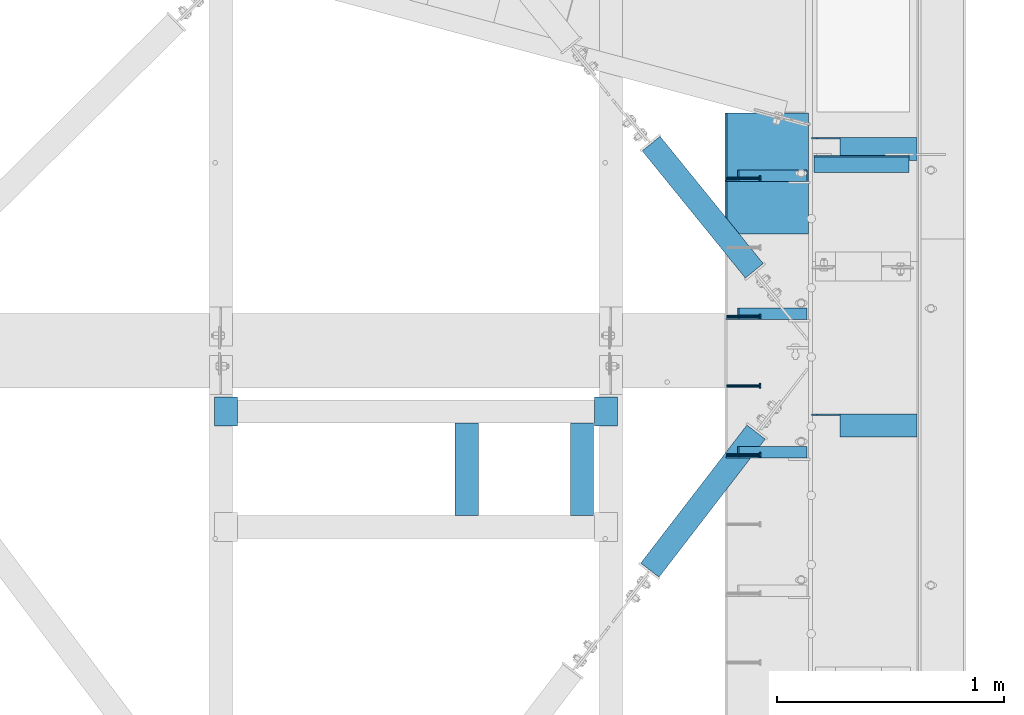
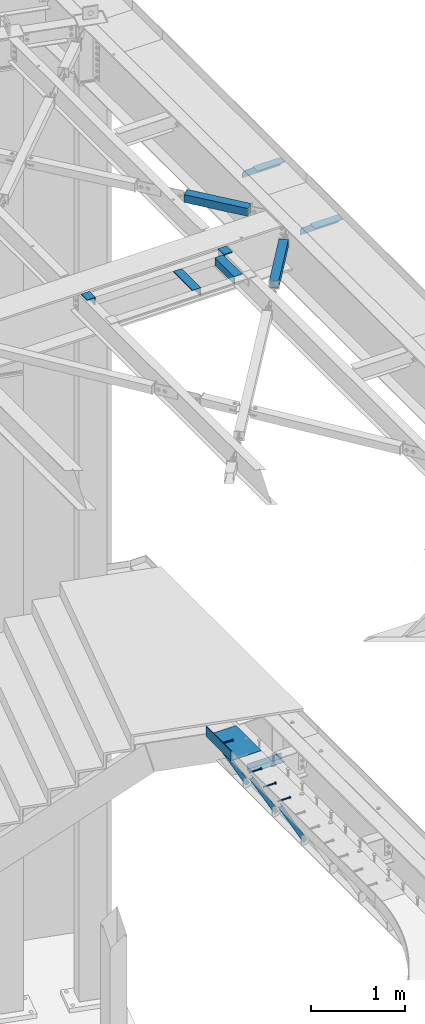
# One storey, part 1381 of 1763: 14 beams, 3 members, 10 elements without a shape of their own.
"""IFC2X3 building model written with IfcOpenShell, lengths in millimetres."""

import ifcopenshell
import ifcopenshell.guid

model = None  # the IFC model being written
_history = None  # IfcOwnerHistory: only IFC2X3 demands one
_inside = {}  # id of a spatial element -> (the spatial element, [elements in it])
_under = {}  # id of a project, library or spatial element -> (it, [spatial elements below it])
_declared = {}  # id of a project -> (the project, [libraries it declares])
_typed = {}  # id of a type object -> (the type object, [elements of that type])
_made_of = {}  # id of a material, layer set ... -> (it, [elements and type objects made of it])


def new_model(schema):
    """Start an empty IFC model of exactly this schema.

    Asked for "IFC4X3", IfcOpenShell would pick the latest addendum, in which some entities
    have other attributes; the version numbers below select the first issue.
    IFC2X3 requires an IfcOwnerHistory on every rooted entity: one is made here for all.
    """
    global model, _history
    if schema == "IFC4X3":
        model = ifcopenshell.file(schema_version=(4, 3, 0, 0))
    else:
        model = ifcopenshell.file(schema=schema)
    _inside.clear()
    _under.clear()
    _declared.clear()
    _typed.clear()
    _made_of.clear()
    _history = None
    if model.schema == "IFC2X3":
        org = make("IfcOrganization", Name="unknown")
        user = make(
            "IfcPersonAndOrganization",
            ThePerson=make("IfcPerson", FamilyName="unknown"),
            TheOrganization=org,
        )
        app = make(
            "IfcApplication",
            ApplicationDeveloper=org,
            Version="unknown",
            ApplicationFullName="unknown",
            ApplicationIdentifier="unknown",
        )
        _history = make(
            "IfcOwnerHistory",
            OwningUser=user,
            OwningApplication=app,
            ChangeAction="ADDED",
            CreationDate=0,
        )
    return model


def make(cls, **values):
    """One entity of the class cls with the attributes given. An attribute that is None is left unset."""
    return model.create_entity(
        cls, **{name: value for name, value in values.items() if value is not None}
    )


def rooted(cls, **values):
    """An entity with a GlobalId (a new one), such as an element, a storey or a relation."""
    return make(cls, GlobalId=ifcopenshell.guid.new(), OwnerHistory=_history, **values)


def si_unit(unit_type, name, prefix=None):
    """IfcSIUnit, for example si_unit("LENGTHUNIT", "METRE", prefix="MILLI")."""
    return make("IfcSIUnit", UnitType=unit_type, Prefix=prefix, Name=name)


def assignment(units):
    """IfcUnitAssignment: the units of a project."""
    return None if units is None else make("IfcUnitAssignment", Units=units)


def point(xyz):
    """IfcCartesianPoint."""
    return None if xyz is None else make("IfcCartesianPoint", Coordinates=xyz)


def direction(xyz):
    """IfcDirection."""
    return None if xyz is None else make("IfcDirection", DirectionRatios=xyz)


def frame(location, z_axis=None, x_axis=None):
    """IfcAxis2Placement3D, a coordinate frame: its origin and axes. An axis left out is left unset."""
    return make(
        "IfcAxis2Placement3D",
        Location=point(location),
        Axis=direction(z_axis),
        RefDirection=direction(x_axis),
    )


def origin_with_axes():
    """The frame at (0, 0, 0) with the z axis (0, 0, 1) and the x axis (1, 0, 0) written out."""
    return frame((0.0, 0.0, 0.0), z_axis=(0.0, 0.0, 1.0), x_axis=(1.0, 0.0, 0.0))


def place(relative_to, where):
    """IfcLocalPlacement: puts the frame where relative to a parent placement (None: the world)."""
    return make(
        "IfcLocalPlacement", PlacementRelTo=relative_to, RelativePlacement=where
    )


def context(
    kind, dimensions, precision=None, world=None, true_north=None, identifier=None
):
    """IfcGeometricRepresentationContext, for example the 3D "Model" context."""
    return make(
        "IfcGeometricRepresentationContext",
        ContextIdentifier=identifier,
        ContextType=kind,
        CoordinateSpaceDimension=dimensions,
        Precision=precision,
        WorldCoordinateSystem=world,
        TrueNorth=true_north,
    )


def subcontext(parent, identifier, kind, view, scale=None):
    """IfcGeometricRepresentationSubContext, for example "Body" below "Model"."""
    return make(
        "IfcGeometricRepresentationSubContext",
        ContextIdentifier=identifier,
        ContextType=kind,
        ParentContext=parent,
        TargetScale=scale,
        TargetView=view,
    )


def project(units=None, contexts=None):
    """IfcProject with its units and contexts."""
    return rooted(
        "IfcProject",
        Name="project",
        RepresentationContexts=contexts,
        UnitsInContext=assignment(units),
    )


def spatial(cls, under=None, at=None, **own):
    """A site, building, storey or space (cls), placed at a placement, below another one or the project."""
    s = rooted(cls, ObjectPlacement=at, **own)
    if under is not None:
        _under.setdefault(under.id(), (under, []))[1].append(s)
    return s


def faces_of(points, faces, orient=None, outer=None):
    """IfcFace entities. A face is a list of loops; a loop is a list of indices into points, from 0.

    orient and outer hold one flag for each loop. By default every Orientation is true, the
    first loop of a face is its IfcFaceOuterBound and the others are IfcFaceBound.
    """
    made = []
    for i, loops in enumerate(faces):
        bounds = []
        for j, loop in enumerate(loops):
            is_outer = j == 0 if outer is None else outer[i][j]
            bounds.append(
                make(
                    "IfcFaceOuterBound" if is_outer else "IfcFaceBound",
                    Bound=make("IfcPolyLoop", Polygon=[points[k] for k in loop]),
                    Orientation=True if orient is None else orient[i][j],
                )
            )
        made.append(make("IfcFace", Bounds=bounds))
    return made


def faceted_brep(points, faces, orient=None, outer=None, voids=None):
    """IfcFacetedBrep: a solid bounded by flat faces; with voids (closed shells), ...WithVoids."""
    shared = [point(p) for p in points]
    hull = make("IfcClosedShell", CfsFaces=faces_of(shared, faces, orient, outer))
    if voids is None:
        return make("IfcFacetedBrep", Outer=hull)
    return make(
        "IfcFacetedBrepWithVoids",
        Outer=hull,
        Voids=[
            make(cls, CfsFaces=faces_of(shared, fs, o, b)) for cls, fs, o, b in voids
        ],
    )


def shape(context_of_items, identifier, shape_type, items):
    """IfcShapeRepresentation: the items that make up one representation, for example the "Body"."""
    return make(
        "IfcShapeRepresentation",
        ContextOfItems=context_of_items,
        RepresentationIdentifier=identifier,
        RepresentationType=shape_type,
        Items=items,
    )


def material(Name=None, Category=None):
    """IfcMaterial."""
    return make("IfcMaterial", Name=Name, Category=Category)


def made_of(thing, what):
    """Note that an element or type object is made of a material, layer set ...; save() writes the relation."""
    if what is not None:
        _made_of.setdefault(what.id(), (what, []))[1].append(thing)
    return thing


def type_object(cls, material=None, **own):
    """A type object (cls), such as IfcWallType, which elements share."""
    return made_of(rooted(cls, **own), material)


def element(
    cls,
    number,
    at=None,
    inside=None,
    cuts=None,
    type_object=None,
    material=None,
    context=None,
    identifier="Body",
    shape_type=None,
    held_by="IfcProductDefinitionShape",
    body=None,
    shapes=None,
    **own,
):
    """One element of the class cls, such as IfcWall. Its Tag is "e" and its number.

    at: its placement. inside: the storey or other place that contains it. cuts: it is an
    opening in that element (IfcRelVoidsElement). A single representation is given by context,
    identifier, shape_type and body (its items); several are given by shapes. held_by: the class
    of the entity that holds the representations. save() writes the other relations.
    """
    e = rooted(cls, Tag="e%d" % number, ObjectPlacement=at, **own)
    if body is not None:
        shapes = [shape(context, identifier, shape_type, body)]
    if shapes is not None:
        e.Representation = make(held_by, Representations=shapes)
    if inside is not None:
        _inside.setdefault(inside.id(), (inside, []))[1].append(e)
    if cuts is not None:
        rooted(
            "IfcRelVoidsElement", RelatingBuildingElement=cuts, RelatedOpeningElement=e
        )
    if type_object is not None:
        _typed.setdefault(type_object.id(), (type_object, []))[1].append(e)
    return made_of(e, material)


def aggregate(whole, parts):
    """IfcRelAggregates: a whole, such as a stair, and the parts it consists of."""
    return rooted("IfcRelAggregates", RelatingObject=whole, RelatedObjects=parts)


def save(model, path):
    """Write the relations noted so far, then the file.

    IfcRelAggregates (storeys below a building ...), IfcRelContainedInSpatialStructure (elements
    in a storey), IfcRelDefinesByType, IfcRelAssociatesMaterial and IfcRelDeclares: one each for
    every whole, place, type object, material and project.
    """
    for whole, parts in _under.values():
        aggregate(whole, parts)
    for where, things in _inside.values():
        rooted(
            "IfcRelContainedInSpatialStructure",
            RelatedElements=things,
            RelatingStructure=where,
        )
    for kind, things in _typed.values():
        rooted("IfcRelDefinesByType", RelatedObjects=things, RelatingType=kind)
    for what, things in _made_of.values():
        rooted("IfcRelAssociatesMaterial", RelatedObjects=things, RelatingMaterial=what)
    for by, libraries in _declared.values():
        rooted("IfcRelDeclares", RelatingContext=by, RelatedDefinitions=libraries)
    model.write(path)


model = new_model("IFC2X3")

# Units and contexts
model_context = context("Model", 3, precision=1e-05, world=origin_with_axes())
body_context = subcontext(model_context, "Body", "Model", "MODEL_VIEW")
ifc_project = project(units=[si_unit("LENGTHUNIT", "METRE", prefix="MILLI"), si_unit("AREAUNIT", "SQUARE_METRE"), si_unit("VOLUMEUNIT", "CUBIC_METRE"), si_unit("MASSUNIT", "GRAM", prefix="KILO"), si_unit("TIMEUNIT", "SECOND"), si_unit("PLANEANGLEUNIT", "RADIAN"), si_unit("SOLIDANGLEUNIT", "STERADIAN"), si_unit("THERMODYNAMICTEMPERATUREUNIT", "DEGREE_CELSIUS"), si_unit("LUMINOUSINTENSITYUNIT", "LUMEN")], contexts=[model_context])

# Site, building, storey
site_placement = place(None, origin_with_axes())
site = spatial("IfcSite", under=ifc_project, at=site_placement, CompositionType="ELEMENT")
building_placement = place(site_placement, origin_with_axes())
building = spatial("IfcBuilding", under=site, at=building_placement, Name="Undefined", CompositionType="ELEMENT")
storey_placement = place(building_placement, origin_with_axes())
storey = spatial("IfcBuildingStorey", under=building, at=storey_placement, Name="Undefined", CompositionType="ELEMENT", Elevation=0.0)

# Assembly, beam
assembly_1_placement = place(storey_placement, origin_with_axes())
assembly_1 = element("IfcElementAssembly", 1, at=assembly_1_placement, inside=storey, Name="HEADED STUD ANCHOR", AssemblyPlace="NOTDEFINED", PredefinedType="RIGID_FRAME")
ifc_material_1 = material(Name="STEEL/A108")
beam_type_1 = type_object("IfcBeamType", PredefinedType="NOTDEFINED")
beam_1_placement = place(assembly_1_placement, frame((-22037.1277822587, 58462.06875, 5264.15000152588), z_axis=(0.0, 0.0, 1.0), x_axis=(1.0, 0.0, 0.0)))
beam_1 = element("IfcBeam", 2, at=beam_1_placement, type_object=beam_type_1, material=ifc_material_1, Name="HEADED STUD ANCHOR", context=body_context, shape_type="Brep", body=[
    faceted_brep([(0.0, -3.1800000667572, 5.5), (0.0, -5.5, 3.1800000667572), (141.732000000002, -5.5, 3.1800000667572), (141.732000000002, -3.1800000667572, 5.5), (0.0, -6.34999999999491, 1.45519152283669e-11), (141.732000000002, -6.34999990463257, 0.0), (0.0, -5.5, -3.1800000667572), (141.732000000002, -5.5, -3.1800000667572), (0.0, -3.1800000667572, -5.5), (141.732000000002, -3.1800000667572, -5.5), (0.0, 0.0, -6.34999990463257), (141.732000000002, 0.0, -6.34999990463257), (0.0, 3.1800000667572, -5.5), (141.732000000002, 3.1800000667572, -5.5), (0.0, 5.5, -3.1800000667572), (141.732000000002, 5.5, -3.1800000667572), (0.0, 6.34999999999491, -2.91038304567337e-11), (141.732000000002, 6.34999990463257, 0.0), (0.0, 5.5, 3.1800000667572), (141.732000000002, 5.5, 3.1800000667572), (0.0, 3.1800000667572, 5.5), (141.732000000002, 3.1800000667572, 5.5), (0.0, 0.0, 6.34999990463257), (141.732000000002, 0.0, 6.34999990463257), (144.780000000001, -10.9899997711182, 6.34999990463257), (144.780000000001, -6.34000015258789, 10.9899997711182), (144.780000000001, -12.6999998092651, 0.0), (144.780000000001, -10.9899997711182, -6.34999990463257), (144.780000000001, -6.34000015258789, -10.9899997711182), (144.780000000001, 0.0, -12.6899995803833), (144.780000000001, 6.34000015258789, -10.9899997711182), (144.780000000001, 10.9899997711182, -6.34999990463257), (144.780000000001, 12.6999998092651, 0.0), (144.780000000001, 10.9899997711182, 6.34999990463257), (144.780000000001, 6.34000015258789, 10.9899997711182), (144.780000000001, 0.0, 12.6899995803833), (152.400000000001, -10.9899997711182, 6.34999990463257), (152.400000000001, -6.34000015258789, 10.9899997711182), (152.400000000001, -12.6999998092651, 0.0), (152.400000000001, -10.9899997711182, -6.34999990463257), (152.400000000001, -6.34000015258789, -10.9899997711182), (152.400000000001, 0.0, -12.6899995803833), (152.400000000001, 6.34000015258789, -10.9899997711182), (152.400000000001, 10.9899997711182, -6.34999990463257), (152.400000000001, 12.6999998092651, 0.0), (152.400000000001, 10.9899997711182, 6.34999990463257), (152.400000000001, 6.34000015258789, 10.9899997711182), (152.400000000001, 0.0, 12.6899995803833)], [[[0, 1, 2, 3]], [[1, 4, 5, 2]], [[4, 6, 7, 5]], [[6, 8, 9, 7]], [[8, 10, 11, 9]], [[10, 12, 13, 11]], [[12, 14, 15, 13]], [[14, 16, 17, 15]], [[16, 18, 19, 17]], [[18, 20, 21, 19]], [[20, 22, 23, 21]], [[22, 0, 3, 23]], [[22, 20, 18, 16, 14, 12, 10, 8, 6, 4, 1, 0]], [[3, 2, 24, 25]], [[2, 5, 26, 24]], [[5, 7, 27, 26]], [[7, 9, 28, 27]], [[9, 11, 29, 28]], [[11, 13, 30, 29]], [[13, 15, 31, 30]], [[15, 17, 32, 31]], [[17, 19, 33, 32]], [[19, 21, 34, 33]], [[21, 23, 35, 34]], [[23, 3, 25, 35]], [[25, 24, 36, 37]], [[24, 26, 38, 36]], [[26, 27, 39, 38]], [[27, 28, 40, 39]], [[28, 29, 41, 40]], [[29, 30, 42, 41]], [[30, 31, 43, 42]], [[31, 32, 44, 43]], [[32, 33, 45, 44]], [[33, 34, 46, 45]], [[34, 35, 47, 46]], [[35, 25, 37, 47]], [[38, 39, 40, 41, 42, 43, 44, 45, 46, 47, 37, 36]]]),
])
aggregate(assembly_1, [beam_1])

assembly_2_placement = place(storey_placement, origin_with_axes())
assembly_2 = element("IfcElementAssembly", 3, at=assembly_2_placement, inside=storey, Name="HEADED STUD ANCHOR", AssemblyPlace="NOTDEFINED", PredefinedType="RIGID_FRAME")
beam_2_placement = place(assembly_2_placement, frame((-22037.1277822587, 57852.46875, 5264.15000152588), z_axis=(0.0, 0.0, 1.0), x_axis=(1.0, 0.0, 0.0)))
beam_2 = element("IfcBeam", 4, at=beam_2_placement, type_object=beam_type_1, material=ifc_material_1, Name="HEADED STUD ANCHOR", context=body_context, shape_type="Brep", body=[
    faceted_brep([(0.0, -3.1800000667572, 5.5), (0.0, -5.5, 3.1800000667572), (141.732000000002, -5.5, 3.1800000667572), (141.732000000002, -3.1800000667572, 5.5), (0.0, -6.34999999999491, 1.45519152283669e-11), (141.732000000002, -6.34999990463257, 0.0), (0.0, -5.5, -3.1800000667572), (141.732000000002, -5.5, -3.1800000667572), (0.0, -3.1800000667572, -5.5), (141.732000000002, -3.1800000667572, -5.5), (0.0, 0.0, -6.34999990463257), (141.732000000002, 0.0, -6.34999990463257), (0.0, 3.1800000667572, -5.5), (141.732000000002, 3.1800000667572, -5.5), (0.0, 5.5, -3.1800000667572), (141.732000000002, 5.5, -3.1800000667572), (0.0, 6.34999999999491, -2.91038304567337e-11), (141.732000000002, 6.34999990463257, 0.0), (0.0, 5.5, 3.1800000667572), (141.732000000002, 5.5, 3.1800000667572), (0.0, 3.1800000667572, 5.5), (141.732000000002, 3.1800000667572, 5.5), (0.0, 0.0, 6.34999990463257), (141.732000000002, 0.0, 6.34999990463257), (144.780000000001, -10.9899997711182, 6.34999990463257), (144.780000000001, -6.34000015258789, 10.9899997711182), (144.780000000001, -12.6999998092651, 0.0), (144.780000000001, -10.9899997711182, -6.34999990463257), (144.780000000001, -6.34000015258789, -10.9899997711182), (144.780000000001, 0.0, -12.6899995803833), (144.780000000001, 6.34000015258789, -10.9899997711182), (144.780000000001, 10.9899997711182, -6.34999990463257), (144.780000000001, 12.6999998092651, 0.0), (144.780000000001, 10.9899997711182, 6.34999990463257), (144.780000000001, 6.34000015258789, 10.9899997711182), (144.780000000001, 0.0, 12.6899995803833), (152.400000000001, -10.9899997711182, 6.34999990463257), (152.400000000001, -6.34000015258789, 10.9899997711182), (152.400000000001, -12.6999998092651, 0.0), (152.400000000001, -10.9899997711182, -6.34999990463257), (152.400000000001, -6.34000015258789, -10.9899997711182), (152.400000000001, 0.0, -12.6899995803833), (152.400000000001, 6.34000015258789, -10.9899997711182), (152.400000000001, 10.9899997711182, -6.34999990463257), (152.400000000001, 12.6999998092651, 0.0), (152.400000000001, 10.9899997711182, 6.34999990463257), (152.400000000001, 6.34000015258789, 10.9899997711182), (152.400000000001, 0.0, 12.6899995803833)], [[[0, 1, 2, 3]], [[1, 4, 5, 2]], [[4, 6, 7, 5]], [[6, 8, 9, 7]], [[8, 10, 11, 9]], [[10, 12, 13, 11]], [[12, 14, 15, 13]], [[14, 16, 17, 15]], [[16, 18, 19, 17]], [[18, 20, 21, 19]], [[20, 22, 23, 21]], [[22, 0, 3, 23]], [[22, 20, 18, 16, 14, 12, 10, 8, 6, 4, 1, 0]], [[3, 2, 24, 25]], [[2, 5, 26, 24]], [[5, 7, 27, 26]], [[7, 9, 28, 27]], [[9, 11, 29, 28]], [[11, 13, 30, 29]], [[13, 15, 31, 30]], [[15, 17, 32, 31]], [[17, 19, 33, 32]], [[19, 21, 34, 33]], [[21, 23, 35, 34]], [[23, 3, 25, 35]], [[25, 24, 36, 37]], [[24, 26, 38, 36]], [[26, 27, 39, 38]], [[27, 28, 40, 39]], [[28, 29, 41, 40]], [[29, 30, 42, 41]], [[30, 31, 43, 42]], [[31, 32, 44, 43]], [[32, 33, 45, 44]], [[33, 34, 46, 45]], [[34, 35, 47, 46]], [[35, 25, 37, 47]], [[38, 39, 40, 41, 42, 43, 44, 45, 46, 47, 37, 36]]]),
])
aggregate(assembly_2, [beam_2])

assembly_3_placement = place(storey_placement, origin_with_axes())
assembly_3 = element("IfcElementAssembly", 5, at=assembly_3_placement, inside=storey, Name="HEADED STUD ANCHOR", AssemblyPlace="NOTDEFINED", PredefinedType="RIGID_FRAME")
beam_3_placement = place(assembly_3_placement, frame((-22037.1277822587, 57547.66875, 5264.15000152588), z_axis=(0.0, 0.0, 1.0), x_axis=(1.0, 0.0, 0.0)))
beam_3 = element("IfcBeam", 6, at=beam_3_placement, type_object=beam_type_1, material=ifc_material_1, Name="HEADED STUD ANCHOR", context=body_context, shape_type="Brep", body=[
    faceted_brep([(0.0, -3.1800000667572, 5.5), (0.0, -5.5, 3.1800000667572), (141.732000000002, -5.5, 3.1800000667572), (141.732000000002, -3.1800000667572, 5.5), (0.0, -6.34999999999491, 1.45519152283669e-11), (141.732000000002, -6.34999990463257, 0.0), (0.0, -5.5, -3.1800000667572), (141.732000000002, -5.5, -3.1800000667572), (0.0, -3.1800000667572, -5.5), (141.732000000002, -3.1800000667572, -5.5), (0.0, 0.0, -6.34999990463257), (141.732000000002, 0.0, -6.34999990463257), (0.0, 3.1800000667572, -5.5), (141.732000000002, 3.1800000667572, -5.5), (0.0, 5.5, -3.1800000667572), (141.732000000002, 5.5, -3.1800000667572), (0.0, 6.34999999999491, -2.91038304567337e-11), (141.732000000002, 6.34999990463257, 0.0), (0.0, 5.5, 3.1800000667572), (141.732000000002, 5.5, 3.1800000667572), (0.0, 3.1800000667572, 5.5), (141.732000000002, 3.1800000667572, 5.5), (0.0, 0.0, 6.34999990463257), (141.732000000002, 0.0, 6.34999990463257), (144.780000000001, -10.9899997711182, 6.34999990463257), (144.780000000001, -6.34000015258789, 10.9899997711182), (144.780000000001, -12.6999998092651, 0.0), (144.780000000001, -10.9899997711182, -6.34999990463257), (144.780000000001, -6.34000015258789, -10.9899997711182), (144.780000000001, 0.0, -12.6899995803833), (144.780000000001, 6.34000015258789, -10.9899997711182), (144.780000000001, 10.9899997711182, -6.34999990463257), (144.780000000001, 12.6999998092651, 0.0), (144.780000000001, 10.9899997711182, 6.34999990463257), (144.780000000001, 6.34000015258789, 10.9899997711182), (144.780000000001, 0.0, 12.6899995803833), (152.400000000001, -10.9899997711182, 6.34999990463257), (152.400000000001, -6.34000015258789, 10.9899997711182), (152.400000000001, -12.6999998092651, 0.0), (152.400000000001, -10.9899997711182, -6.34999990463257), (152.400000000001, -6.34000015258789, -10.9899997711182), (152.400000000001, 0.0, -12.6899995803833), (152.400000000001, 6.34000015258789, -10.9899997711182), (152.400000000001, 10.9899997711182, -6.34999990463257), (152.400000000001, 12.6999998092651, 0.0), (152.400000000001, 10.9899997711182, 6.34999990463257), (152.400000000001, 6.34000015258789, 10.9899997711182), (152.400000000001, 0.0, 12.6899995803833)], [[[0, 1, 2, 3]], [[1, 4, 5, 2]], [[4, 6, 7, 5]], [[6, 8, 9, 7]], [[8, 10, 11, 9]], [[10, 12, 13, 11]], [[12, 14, 15, 13]], [[14, 16, 17, 15]], [[16, 18, 19, 17]], [[18, 20, 21, 19]], [[20, 22, 23, 21]], [[22, 0, 3, 23]], [[22, 20, 18, 16, 14, 12, 10, 8, 6, 4, 1, 0]], [[3, 2, 24, 25]], [[2, 5, 26, 24]], [[5, 7, 27, 26]], [[7, 9, 28, 27]], [[9, 11, 29, 28]], [[11, 13, 30, 29]], [[13, 15, 31, 30]], [[15, 17, 32, 31]], [[17, 19, 33, 32]], [[19, 21, 34, 33]], [[21, 23, 35, 34]], [[23, 3, 25, 35]], [[25, 24, 36, 37]], [[24, 26, 38, 36]], [[26, 27, 39, 38]], [[27, 28, 40, 39]], [[28, 29, 41, 40]], [[29, 30, 42, 41]], [[30, 31, 43, 42]], [[31, 32, 44, 43]], [[32, 33, 45, 44]], [[33, 34, 46, 45]], [[34, 35, 47, 46]], [[35, 25, 37, 47]], [[38, 39, 40, 41, 42, 43, 44, 45, 46, 47, 37, 36]]]),
])
aggregate(assembly_3, [beam_3])

assembly_4_placement = place(storey_placement, origin_with_axes())
assembly_4 = element("IfcElementAssembly", 7, at=assembly_4_placement, inside=storey, Name="HEADED STUD ANCHOR", AssemblyPlace="NOTDEFINED", PredefinedType="RIGID_FRAME")
beam_4_placement = place(assembly_4_placement, frame((-22037.1277822587, 57242.86875, 5264.15000152588), z_axis=(0.0, 0.0, 1.0), x_axis=(1.0, 0.0, 0.0)))
beam_4 = element("IfcBeam", 8, at=beam_4_placement, type_object=beam_type_1, material=ifc_material_1, Name="HEADED STUD ANCHOR", context=body_context, shape_type="Brep", body=[
    faceted_brep([(0.0, -3.1800000667572, 5.5), (0.0, -5.5, 3.1800000667572), (141.732000000002, -5.5, 3.1800000667572), (141.732000000002, -3.1800000667572, 5.5), (0.0, -6.34999999999491, 1.45519152283669e-11), (141.732000000002, -6.34999990463257, 0.0), (0.0, -5.5, -3.1800000667572), (141.732000000002, -5.5, -3.1800000667572), (0.0, -3.1800000667572, -5.5), (141.732000000002, -3.1800000667572, -5.5), (0.0, 0.0, -6.34999990463257), (141.732000000002, 0.0, -6.34999990463257), (0.0, 3.1800000667572, -5.5), (141.732000000002, 3.1800000667572, -5.5), (0.0, 5.5, -3.1800000667572), (141.732000000002, 5.5, -3.1800000667572), (0.0, 6.34999999999491, -2.91038304567337e-11), (141.732000000002, 6.34999990463257, 0.0), (0.0, 5.5, 3.1800000667572), (141.732000000002, 5.5, 3.1800000667572), (0.0, 3.1800000667572, 5.5), (141.732000000002, 3.1800000667572, 5.5), (0.0, 0.0, 6.34999990463257), (141.732000000002, 0.0, 6.34999990463257), (144.780000000001, -10.9899997711182, 6.34999990463257), (144.780000000001, -6.34000015258789, 10.9899997711182), (144.780000000001, -12.6999998092651, 0.0), (144.780000000001, -10.9899997711182, -6.34999990463257), (144.780000000001, -6.34000015258789, -10.9899997711182), (144.780000000001, 0.0, -12.6899995803833), (144.780000000001, 6.34000015258789, -10.9899997711182), (144.780000000001, 10.9899997711182, -6.34999990463257), (144.780000000001, 12.6999998092651, 0.0), (144.780000000001, 10.9899997711182, 6.34999990463257), (144.780000000001, 6.34000015258789, 10.9899997711182), (144.780000000001, 0.0, 12.6899995803833), (152.400000000001, -10.9899997711182, 6.34999990463257), (152.400000000001, -6.34000015258789, 10.9899997711182), (152.400000000001, -12.6999998092651, 0.0), (152.400000000001, -10.9899997711182, -6.34999990463257), (152.400000000001, -6.34000015258789, -10.9899997711182), (152.400000000001, 0.0, -12.6899995803833), (152.400000000001, 6.34000015258789, -10.9899997711182), (152.400000000001, 10.9899997711182, -6.34999990463257), (152.400000000001, 12.6999998092651, 0.0), (152.400000000001, 10.9899997711182, 6.34999990463257), (152.400000000001, 6.34000015258789, 10.9899997711182), (152.400000000001, 0.0, 12.6899995803833)], [[[0, 1, 2, 3]], [[1, 4, 5, 2]], [[4, 6, 7, 5]], [[6, 8, 9, 7]], [[8, 10, 11, 9]], [[10, 12, 13, 11]], [[12, 14, 15, 13]], [[14, 16, 17, 15]], [[16, 18, 19, 17]], [[18, 20, 21, 19]], [[20, 22, 23, 21]], [[22, 0, 3, 23]], [[22, 20, 18, 16, 14, 12, 10, 8, 6, 4, 1, 0]], [[3, 2, 24, 25]], [[2, 5, 26, 24]], [[5, 7, 27, 26]], [[7, 9, 28, 27]], [[9, 11, 29, 28]], [[11, 13, 30, 29]], [[13, 15, 31, 30]], [[15, 17, 32, 31]], [[17, 19, 33, 32]], [[19, 21, 34, 33]], [[21, 23, 35, 34]], [[23, 3, 25, 35]], [[25, 24, 36, 37]], [[24, 26, 38, 36]], [[26, 27, 39, 38]], [[27, 28, 40, 39]], [[28, 29, 41, 40]], [[29, 30, 42, 41]], [[30, 31, 43, 42]], [[31, 32, 44, 43]], [[32, 33, 45, 44]], [[33, 34, 46, 45]], [[34, 35, 47, 46]], [[35, 25, 37, 47]], [[38, 39, 40, 41, 42, 43, 44, 45, 46, 47, 37, 36]]]),
])
aggregate(assembly_4, [beam_4])

# Assembly, members
assembly_5_placement = place(storey_placement, origin_with_axes())
assembly_5 = element("IfcElementAssembly", 9, at=assembly_5_placement, inside=storey, Name="BEAM", AssemblyPlace="NOTDEFINED", PredefinedType="RIGID_FRAME")
ifc_material_2 = material(Name="STEEL/A36")
member_type = type_object("IfcMemberType", Name="L2X2X1/4", PredefinedType="NOTDEFINED")
member_1_placement = place(assembly_5_placement, frame((-22018.0026564191, 57254.775, 5206.55507545536), z_axis=(-0.875905243340155, 0.0, -0.482483165187371), x_axis=(0.482483165187372, 0.0, -0.875905243340155)))
member_1 = element("IfcMember", 10, at=member_1_placement, type_object=member_type, material=ifc_material_2, Name="ANGLE", ObjectType="L2X2X1/4", context=body_context, shape_type="Brep", body=[
    faceted_brep([(27.9826493408473, 25.4000000000015, -25.4000000000015), (1.45519152283669e-11, 25.4000000000015, 25.3999999999796), (646.991234315485, 25.4000000000015, 25.4000000007727), (646.991234315505, 25.4000000000015, -25.3999999992993), (1.45519152283669e-11, 19.0499999999993, 25.3999999999796), (646.991234315485, 19.0500000000029, 25.4000000007727), (24.4848192607787, 19.0500000000029, -19.0499999999993), (646.991234315503, 19.0500000000029, -19.0499999992862), (24.4848192607787, -25.4000000000015, -19.0499999999993), (646.991234315503, -25.4000000000015, -19.0499999992862), (27.9826493408473, -25.4000000000015, -25.4000000000015), (646.991234315505, -25.4000000000015, -25.3999999992993)], [[[0, 1, 2, 3]], [[1, 4, 5, 2]], [[4, 6, 7, 5]], [[6, 8, 9, 7]], [[8, 10, 11, 9]], [[10, 0, 3, 11]], [[5, 7, 9, 11, 3, 2]], [[10, 8, 6, 4, 1, 0]]]),
])
member_2_placement = place(assembly_5_placement, frame((-22018.0026564191, 57864.375, 5206.55507545536), z_axis=(-0.875905243340155, 0.0, -0.482483165187371), x_axis=(0.482483165187372, 0.0, -0.875905243340155)))
member_2 = element("IfcMember", 11, at=member_2_placement, type_object=member_type, material=ifc_material_2, Name="ANGLE", ObjectType="L2X2X1/4", context=body_context, shape_type="Brep", body=[
    faceted_brep([(27.9826493408473, 25.4000000000015, -25.4000000000015), (1.45519152283669e-11, 25.4000000000015, 25.3999999999796), (646.991234315485, 25.4000000000015, 25.4000000007727), (646.991234315505, 25.4000000000015, -25.3999999992993), (1.45519152283669e-11, 19.0499999999993, 25.3999999999796), (646.991234315485, 19.0500000000029, 25.4000000007727), (24.4848192607787, 19.0500000000029, -19.0499999999993), (646.991234315503, 19.0500000000029, -19.0499999992862), (24.4848192607787, -25.4000000000015, -19.0499999999993), (646.991234315503, -25.4000000000015, -19.0499999992862), (27.9826493408473, -25.4000000000015, -25.4000000000015), (646.991234315505, -25.4000000000015, -25.3999999992993)], [[[0, 1, 2, 3]], [[1, 4, 5, 2]], [[4, 6, 7, 5]], [[6, 8, 9, 7]], [[8, 10, 11, 9]], [[10, 0, 3, 11]], [[5, 7, 9, 11, 3, 2]], [[10, 8, 6, 4, 1, 0]]]),
])
member_3_placement = place(assembly_5_placement, frame((-22018.0492336449, 58473.975, 5206.55507545536), z_axis=(-0.875905243340155, 0.0, -0.482483165187371), x_axis=(0.482483165187372, 0.0, -0.875905243340155)))
member_3 = element("IfcMember", 12, at=member_3_placement, type_object=member_type, material=ifc_material_2, Name="ANGLE", ObjectType="L2X2X1/4", context=body_context, shape_type="Brep", body=[
    faceted_brep([(27.9826493408473, 25.4000000000015, -25.4000000000015), (1.45519152283669e-11, 25.4000000000015, 25.3999999999796), (646.991234315485, 25.4000000000015, 25.4000000007727), (646.991234315505, 25.4000000000015, -25.3999999992993), (1.45519152283669e-11, 19.0499999999993, 25.3999999999796), (646.991234315485, 19.0500000000029, 25.4000000007727), (24.4848192607787, 19.0500000000029, -19.0499999999993), (646.991234315503, 19.0500000000029, -19.0499999992862), (24.4848192607787, -25.4000000000015, -19.0499999999993), (646.991234315503, -25.4000000000015, -19.0499999992862), (27.9826493408473, -25.4000000000015, -25.4000000000015), (646.991234315505, -25.4000000000015, -25.3999999992993)], [[[0, 1, 2, 3]], [[1, 4, 5, 2]], [[4, 6, 7, 5]], [[6, 8, 9, 7]], [[8, 10, 11, 9]], [[10, 0, 3, 11]], [[5, 7, 9, 11, 3, 2]], [[10, 8, 6, 4, 1, 0]]]),
])

# Assembly, beams
assembly_6_placement = place(storey_placement, origin_with_axes())
assembly_6 = element("IfcElementAssembly", 13, at=assembly_6_placement, inside=storey, Name="BEAM", AssemblyPlace="NOTDEFINED", PredefinedType="RIGID_FRAME")
beam_type_2 = type_object("IfcBeamType", Name="L4X4X1/4", PredefinedType="NOTDEFINED")
beam_5_placement = place(assembly_6_placement, frame((-21196.9646113448, 58591.4499880058, 12395.2), z_axis=(0.0, 0.0, -1.0), x_axis=(-1.0, 0.0, 0.0)))
beam_5 = element("IfcBeam", 14, at=beam_5_placement, type_object=beam_type_2, material=ifc_material_2, Name="BRACE", ObjectType="L4X4X1/4", context=body_context, shape_type="Brep", body=[
    faceted_brep([(1.96450855582952e-10, -50.8000000000338, -44.4499999999534), (2.11002770811319e-10, -50.8000000000357, -50.799999999952), (339.725506103507, -50.8000000000029, -50.7999999999993), (339.725506103507, -50.8000000000029, -44.4500000000007), (-3.63797880709171e-11, 50.8000000000011, -50.8000000000538), (339.725506103507, 50.8000000000029, -50.7999999999993), (339.725506103507, 44.4499999999971, -34.9250007629398), (339.725506103507, 50.8000000000029, -34.9250007629398), (441.325002944937, 50.8000000000029, -34.9250007629398), (441.325002944937, 44.4499999999971, -34.9250007629398), (339.725506103507, 44.4499999999971, -44.4500000000007), (-2.18278728425503e-11, 44.4500000000007, -44.450000000048), (-1.81898940354586e-10, 44.4500000000371, 50.7999999999374), (-1.96450855582952e-10, 50.8000000000393, 50.7999999999374), (466.725006103512, 44.4499999999971, 50.7999999999993), (466.725006103512, 50.8000000000029, 50.7999999999993), (466.725002563468, 50.8000000000029, -9.52499923706091), (466.725002563468, 44.4499999999971, -9.52499923706091)], [[[0, 1, 2, 3]], [[1, 4, 5, 2]], [[6, 7, 8, 9]], [[10, 3, 2, 5, 7, 6]], [[11, 0, 3, 10]], [[1, 0, 11, 12, 13, 4]], [[13, 12, 14, 15]], [[8, 7, 5, 4, 13, 15, 16]], [[9, 8, 16, 17]], [[12, 11, 10, 6, 9, 17, 14]], [[16, 15, 14, 17]]]),
])
beam_6_placement = place(assembly_6_placement, frame((-21196.9646113448, 57372.2499880058, 12395.2), z_axis=(0.0, 0.0, -1.0), x_axis=(-1.0, 0.0, 0.0)))
beam_6 = element("IfcBeam", 15, at=beam_6_placement, type_object=beam_type_2, material=ifc_material_2, Name="BRACE", ObjectType="L4X4X1/4", context=body_context, shape_type="Brep", body=[
    faceted_brep([(1.96450855582952e-10, -50.8000000000338, -44.4499999999534), (2.11002770811319e-10, -50.8000000000357, -50.799999999952), (339.725506103507, -50.8000000000029, -50.7999999999993), (339.725506103507, -50.8000000000029, -44.4500000000007), (-3.63797880709171e-11, 50.8000000000011, -50.8000000000538), (339.725506103507, 50.8000000000029, -50.7999999999993), (339.725506103507, 44.4499999999971, -34.9250007629398), (339.725506103507, 50.8000000000029, -34.9250007629398), (441.325002944937, 50.8000000000029, -34.9250007629398), (441.325002944937, 44.4499999999971, -34.9250007629398), (339.725506103507, 44.4499999999971, -44.4500000000007), (-2.18278728425503e-11, 44.4500000000007, -44.450000000048), (-1.81898940354586e-10, 44.4500000000371, 50.7999999999374), (-1.96450855582952e-10, 50.8000000000393, 50.7999999999374), (466.725006103512, 44.4499999999971, 50.7999999999993), (466.725006103512, 50.8000000000029, 50.7999999999993), (466.725002563468, 50.8000000000029, -9.52499923706091), (466.725002563468, 44.4499999999971, -9.52499923706091)], [[[0, 1, 2, 3]], [[1, 4, 5, 2]], [[6, 7, 8, 9]], [[10, 3, 2, 5, 7, 6]], [[11, 0, 3, 10]], [[1, 0, 11, 12, 13, 4]], [[13, 12, 14, 15]], [[8, 7, 5, 4, 13, 15, 16]], [[9, 8, 16, 17]], [[12, 11, 10, 6, 9, 17, 14]], [[16, 15, 14, 17]]]),
])
aggregate(assembly_6, [beam_5, beam_6])

assembly_7_placement = place(storey_placement, origin_with_axes())
assembly_7 = element("IfcElementAssembly", 16, at=assembly_7_placement, inside=storey, Name="FRAME", AssemblyPlace="NOTDEFINED", PredefinedType="RIGID_FRAME")
beam_type_3 = type_object("IfcBeamType", Name="L4X4X3/8", PredefinedType="NOTDEFINED")
beam_7_placement = place(assembly_7_placement, frame((-22568.5546174484, 57370.6625, 12404.725), z_axis=(1.0, 0.0, 0.0), x_axis=(0.0, 1.0, 0.0)))
beam_7 = element("IfcBeam", 17, at=beam_7_placement, type_object=beam_type_3, material=ifc_material_2, Name="ANGLE", ObjectType="L4X4X3/8", context=body_context, shape_type="Brep", body=[
    faceted_brep([(-3.63797880709171e-11, 50.8000000000011, -50.8000000000538), (-1.96450855582952e-10, 50.8000000000393, 50.7999999999374), (127.0, 50.7999999999993, 50.7999999999993), (127.0, 50.7999999999993, -50.7999999999993), (0.0, 41.2749999999996, 50.7999999999993), (127.0, 41.2749999999996, 50.7999999999993), (0.0, 41.2749999999996, -41.2750000000015), (127.0, 41.2749999999996, -41.2750000000015), (0.0, -50.7999999999993, -41.2750000000015), (127.0, -50.7999999999993, -41.2750000000015), (2.11002770811319e-10, -50.8000000000357, -50.799999999952), (127.0, -50.7999999999993, -50.7999999999993)], [[[0, 1, 2, 3]], [[1, 4, 5, 2]], [[4, 6, 7, 5]], [[6, 8, 9, 7]], [[8, 10, 11, 9]], [[10, 0, 3, 11]], [[5, 7, 9, 11, 3, 2]], [[10, 8, 6, 4, 1, 0]]]),
])
beam_8_placement = place(assembly_7_placement, frame((-24242.4246174484, 57370.6625, 12404.725), z_axis=(0.0, 0.0, -1.0), x_axis=(0.0, 1.0, 0.0)))
beam_8 = element("IfcBeam", 18, at=beam_8_placement, type_object=beam_type_3, material=ifc_material_2, Name="ANGLE", ObjectType="L4X4X3/8", context=body_context, shape_type="Brep", body=[
    faceted_brep([(-3.63797880709171e-11, 50.8000000000011, -50.8000000000538), (-1.96450855582952e-10, 50.8000000000393, 50.7999999999374), (127.0, 50.7999999999993, 50.7999999999993), (127.0, 50.7999999999993, -50.7999999999993), (0.0, 41.2749999999996, 50.7999999999993), (127.0, 41.2749999999996, 50.7999999999993), (0.0, 41.2749999999996, -41.2750000000015), (127.0, 41.2749999999996, -41.2750000000015), (0.0, -50.7999999999993, -41.2750000000015), (127.0, -50.7999999999993, -41.2750000000015), (2.11002770811319e-10, -50.8000000000357, -50.799999999952), (127.0, -50.7999999999993, -50.7999999999993)], [[[0, 1, 2, 3]], [[1, 4, 5, 2]], [[4, 6, 7, 5]], [[6, 8, 9, 7]], [[8, 10, 11, 9]], [[10, 0, 3, 11]], [[5, 7, 9, 11, 3, 2]], [[10, 8, 6, 4, 1, 0]]]),
])
beam_9_placement = place(assembly_7_placement, frame((-22673.3296174484, 56976.9625, 12395.2), z_axis=(1.0, 0.0, 0.0), x_axis=(0.0, 1.0, 0.0)))
beam_9 = element("IfcBeam", 19, at=beam_9_placement, type_object=beam_type_3, material=ifc_material_2, Name="ANGLE", ObjectType="L4X4X3/8", context=body_context, shape_type="Brep", body=[
    faceted_brep([(-3.63797880709171e-11, 50.8000000000011, -50.8000000000538), (-1.96450855582952e-10, 50.8000000000393, 50.7999999999374), (406.400000000001, 50.7999999999993, 50.7999999999993), (406.400000000001, 50.7999999999993, -50.7999999999993), (0.0, 41.2749999999996, 50.7999999999993), (406.400000000001, 41.2749999999996, 50.7999999999993), (0.0, 41.2749999999996, -41.2750000000015), (406.400000000001, 41.2749999999996, -41.2750000000015), (0.0, -50.7999999999993, -41.2750000000015), (406.400000000001, -50.7999999999993, -41.2750000000015), (2.11002770811319e-10, -50.8000000000357, -50.799999999952), (406.400000000001, -50.7999999999993, -50.7999999999993)], [[[0, 1, 2, 3]], [[1, 4, 5, 2]], [[4, 6, 7, 5]], [[6, 8, 9, 7]], [[8, 10, 11, 9]], [[10, 0, 3, 11]], [[5, 7, 9, 11, 3, 2]], [[10, 8, 6, 4, 1, 0]]]),
])
beam_10_placement = place(assembly_7_placement, frame((-23181.3296174484, 56976.9625, 12395.2), z_axis=(0.0, 0.0, -1.0), x_axis=(0.0, 1.0, 0.0)))
beam_10 = element("IfcBeam", 20, at=beam_10_placement, type_object=beam_type_3, material=ifc_material_2, Name="ANGLE", ObjectType="L4X4X3/8", context=body_context, shape_type="Brep", body=[
    faceted_brep([(-3.63797880709171e-11, 50.8000000000011, -50.8000000000538), (-1.96450855582952e-10, 50.8000000000393, 50.7999999999374), (406.400000000001, 50.7999999999993, 50.7999999999993), (406.400000000001, 50.7999999999993, -50.7999999999993), (0.0, 41.2749999999996, 50.7999999999993), (406.400000000001, 41.2749999999996, 50.7999999999993), (0.0, 41.2749999999996, -41.2750000000015), (406.400000000001, 41.2749999999996, -41.2750000000015), (0.0, -50.7999999999993, -41.2750000000015), (406.400000000001, -50.7999999999993, -41.2750000000015), (2.11002770811319e-10, -50.8000000000357, -50.799999999952), (406.400000000001, -50.7999999999993, -50.7999999999993)], [[[0, 1, 2, 3]], [[1, 4, 5, 2]], [[4, 6, 7, 5]], [[6, 8, 9, 7]], [[8, 10, 11, 9]], [[10, 0, 3, 11]], [[5, 7, 9, 11, 3, 2]], [[10, 8, 6, 4, 1, 0]]]),
])
aggregate(assembly_7, [beam_7, beam_8, beam_9, beam_10])

# Assembly, beam
assembly_8_placement = place(storey_placement, origin_with_axes())
assembly_8 = element("IfcElementAssembly", 21, at=assembly_8_placement, inside=storey, Name="ANGLE", AssemblyPlace="NOTDEFINED", PredefinedType="RIGID_FRAME")
beam_type_4 = type_object("IfcBeamType", Name="L3X3X1/4", PredefinedType="NOTDEFINED")
beam_11_placement = place(assembly_8_placement, frame((-21652.5771144212, 58524.504003532, 4775.19999995482), z_axis=(0.0, 0.0, 1.0), x_axis=(1.0, 0.0, 0.0)))
beam_11 = element("IfcBeam", 22, at=beam_11_placement, type_object=beam_type_4, material=ifc_material_2, Name="ANGLE", ObjectType="L3X3X1/4", context=body_context, shape_type="Brep", body=[
    faceted_brep([(0.0, 38.0999999999985, -38.1000000000004), (0.0, 38.0999999999985, 38.1000000000004), (419.893746948361, 38.0999999999985, 38.1000000000004), (419.893746948361, 38.0999999999985, -38.1000000000004), (0.0, 31.75, 38.1000000000058), (419.893746948361, 31.75, 38.1000000000004), (0.0, 31.75, -31.75), (419.893746948361, 31.75, -31.75), (0.0, -38.1000000000004, -31.75), (419.893746948361, -38.0999999999985, -31.75), (0.0, -38.0999999999985, -38.1000000000004), (419.893746948361, -38.0999999999985, -38.1000000000004)], [[[0, 1, 2, 3]], [[1, 4, 5, 2]], [[4, 6, 7, 5]], [[6, 8, 9, 7]], [[8, 10, 11, 9]], [[10, 0, 3, 11]], [[5, 7, 9, 11, 3, 2]], [[10, 8, 6, 4, 1, 0]]]),
])
aggregate(assembly_8, [beam_11])

assembly_9_placement = place(storey_placement, origin_with_axes())
assembly_9 = element("IfcElementAssembly", 23, at=assembly_9_placement, inside=storey, Name="H. BRACE", AssemblyPlace="NOTDEFINED", PredefinedType="RIGID_FRAME")
ifc_material_3 = material()
beam_type_5 = type_object("IfcBeamType", Name="HSS4X4X3/8", PredefinedType="NOTDEFINED")
beam_12_placement = place(assembly_9_placement, frame((-22546.3296174484, 56512.8129511845, 12371.3875), z_axis=(0.0, 0.0, 1.0), x_axis=(0.609825086268862, 0.792536033349383, 0.0)))
beam_12 = element("IfcBeam", 24, at=beam_12_placement, type_object=beam_type_5, material=ifc_material_3, Name="H. BRACE", ObjectType="HSS4X4X3/8", context=body_context, shape_type="Brep", body=[
    faceted_brep([(281.393808527519, 41.2750000002852, -41.2749999999996), (281.393808527569, -41.274999999594, -41.2749999999996), (1048.80004301134, -41.2749999986045, -41.2749999999996), (1048.80004301128, 41.2750000012675, -41.2749999999996), (281.393808527569, -41.274999999594, 41.2749999999996), (1048.80004301134, -41.2749999986045, 41.2749999999996), (281.393808527519, 41.2750000002852, 41.2749999999996), (1048.80004301128, 41.2750000012675, 41.2749999999996), (281.393808527511, 50.8000000002721, -50.7999999999993), (281.393808527511, 50.8000000002721, 50.7999999999993), (1048.80004301127, 50.8000000012617, 50.7999999999993), (1048.80004301127, 50.8000000012617, -50.7999999999993), (281.393808527577, -50.7999999995736, 50.7999999999993), (1048.80004301135, -50.7999999985914, 50.7999999999993), (281.393808527577, -50.7999999995736, -50.7999999999993), (1048.80004301135, -50.7999999985914, -50.7999999999993)], [[[0, 1, 2, 3]], [[1, 4, 5, 2]], [[4, 6, 7, 5]], [[6, 0, 3, 7]], [[8, 9, 10, 11]], [[9, 12, 13, 10]], [[12, 14, 15, 13]], [[14, 8, 11, 15]], [[13, 15, 11, 10], [5, 7, 3, 2]], [[14, 12, 9, 8], [6, 4, 1, 0]]]),
])
aggregate(assembly_9, [beam_12])

assembly_10_placement = place(storey_placement, origin_with_axes())
assembly_10 = element("IfcElementAssembly", 25, at=assembly_10_placement, inside=storey, Name="H. BRACE", AssemblyPlace="NOTDEFINED", PredefinedType="RIGID_FRAME")
beam_13_placement = place(assembly_10_placement, frame((-21670.0396174483, 57753.25, 12371.3875), z_axis=(0.0, 0.0, 1.0), x_axis=(-0.630211709758953, 0.776423338702989, 0.0)))
beam_13 = element("IfcBeam", 26, at=beam_13_placement, type_object=beam_type_5, material=ifc_material_3, Name="H. BRACE", ObjectType="HSS4X4X3/8", context=body_context, shape_type="Brep", body=[
    faceted_brep([(387.98661009736, 41.2749999990592, -41.2749999999996), (387.986610097556, -41.2750000008709, -41.2749999999996), (1109.26494809552, -41.2750000025517, -41.2749999999996), (1109.26494809533, 41.2749999973857, -41.2749999999996), (387.986610097556, -41.2750000008709, 41.2749999999996), (1109.26494809552, -41.2750000025517, 41.2749999999996), (387.98661009736, 41.2749999990592, 41.2749999999996), (1109.26494809533, 41.2749999973857, 41.2749999999996), (387.986610097345, 50.799999999057, -50.7999999999993), (387.986610097345, 50.799999999057, 50.7999999999993), (1109.26494809531, 50.7999999973836, 50.7999999999993), (1109.26494809531, 50.7999999973836, -50.7999999999993), (387.986610097578, -50.8000000008687, 50.7999999999993), (1109.26494809554, -50.8000000025386, 50.7999999999993), (387.986610097578, -50.8000000008687, -50.7999999999993), (1109.26494809554, -50.8000000025386, -50.7999999999993)], [[[0, 1, 2, 3]], [[1, 4, 5, 2]], [[4, 6, 7, 5]], [[6, 0, 3, 7]], [[8, 9, 10, 11]], [[9, 12, 13, 10]], [[12, 14, 15, 13]], [[14, 8, 11, 15]], [[13, 15, 11, 10], [5, 7, 3, 2]], [[14, 12, 9, 8], [6, 4, 1, 0]]]),
])
aggregate(assembly_10, [beam_13])

# Beam
beam_type_6 = type_object("IfcBeamType", PredefinedType="NOTDEFINED")
beam_14_placement = place(assembly_5_placement, frame((-22039.9003518186, 58483.4996159619, 5321.3), z_axis=(0.0, -1.0, 0.0), x_axis=(0.0, 0.0, -1.0)))
beam_14 = element("IfcBeam", 27, at=beam_14_placement, type_object=beam_type_6, material=ifc_material_2, Name="BENT PLATE", context=body_context, shape_type="Brep", body=[
    faceted_brep([(0.0, -4.76250000000073, -266.699999999997), (0.0, -4.76250000000073, 266.699999999997), (0.0, 4.76250000000073, 266.699999999997), (0.0, 4.76250000000073, -266.699999999997), (117.474999999999, 4.76250000000073, 266.699999999997), (117.474999999999, 4.76250000000073, -266.699999999997), (126.999999999999, -4.76250000000073, -266.699999999997), (126.999999999999, -4.76250000000073, 266.699999999997), (117.474999999999, 363.516308593749, 266.699999999997), (117.474999999999, 363.516308593749, -266.699999999997), (126.999999999999, 363.516308593749, 266.699999999997), (126.999999999999, 363.516308593749, -266.699999999997)], [[[0, 1, 2, 3]], [[3, 2, 4, 5]], [[1, 0, 6, 7]], [[5, 4, 8, 9]], [[4, 2, 1, 7, 10, 8]], [[7, 6, 11, 10]], [[6, 0, 3, 5, 9, 11]], [[10, 11, 9, 8]]]),
])

aggregate(assembly_5, [member_1, member_2, member_3, beam_14])

save(model, "model.ifc")
